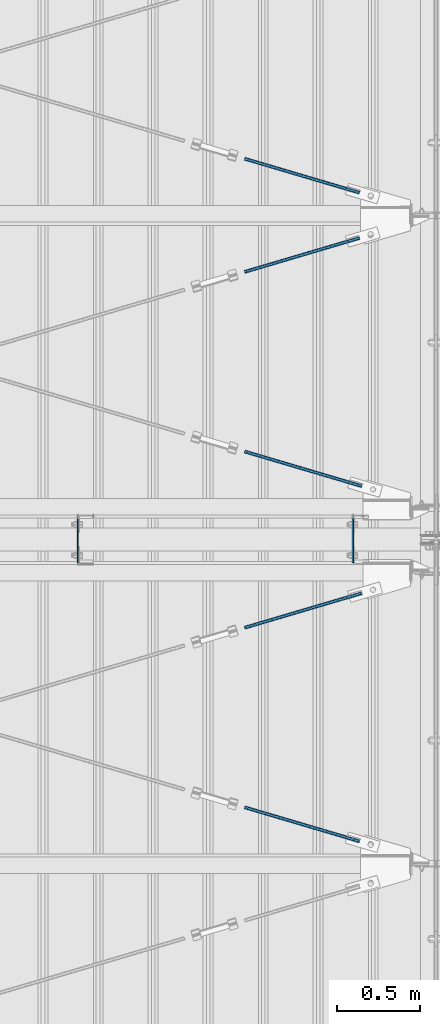
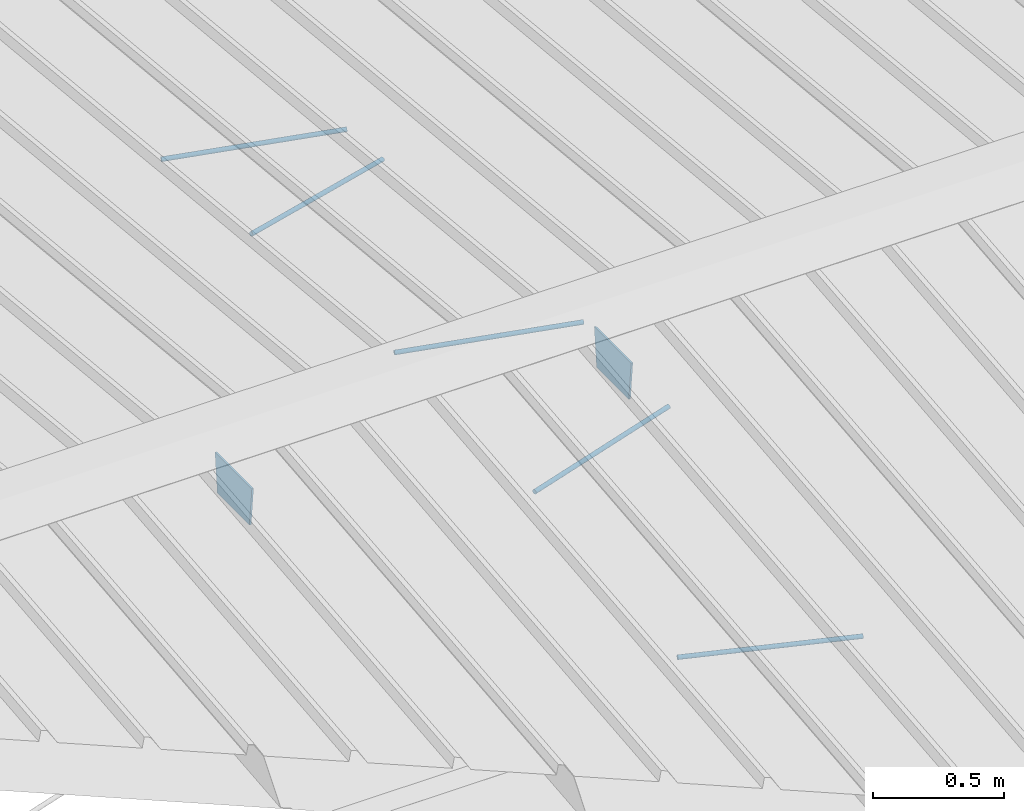
# One storey, part 296 of 709: 7 beams, 5 openings, 7 elements without a shape of their own.
"""IFC4 building model written with IfcOpenShell, lengths in millimetres."""

import ifcopenshell
import ifcopenshell.guid

model = None  # the IFC model being written
_history = None  # IfcOwnerHistory: only IFC2X3 demands one
_inside = {}  # id of a spatial element -> (the spatial element, [elements in it])
_under = {}  # id of a project, library or spatial element -> (it, [spatial elements below it])
_declared = {}  # id of a project -> (the project, [libraries it declares])
_typed = {}  # id of a type object -> (the type object, [elements of that type])
_made_of = {}  # id of a material, layer set ... -> (it, [elements and type objects made of it])


def new_model(schema):
    """Start an empty IFC model of exactly this schema.

    Asked for "IFC4X3", IfcOpenShell would pick the latest addendum, in which some entities
    have other attributes; the version numbers below select the first issue.
    IFC2X3 requires an IfcOwnerHistory on every rooted entity: one is made here for all.
    """
    global model, _history
    if schema == "IFC4X3":
        model = ifcopenshell.file(schema_version=(4, 3, 0, 0))
    else:
        model = ifcopenshell.file(schema=schema)
    _inside.clear()
    _under.clear()
    _declared.clear()
    _typed.clear()
    _made_of.clear()
    _history = None
    if model.schema == "IFC2X3":
        org = make("IfcOrganization", Name="unknown")
        user = make(
            "IfcPersonAndOrganization",
            ThePerson=make("IfcPerson", FamilyName="unknown"),
            TheOrganization=org,
        )
        app = make(
            "IfcApplication",
            ApplicationDeveloper=org,
            Version="unknown",
            ApplicationFullName="unknown",
            ApplicationIdentifier="unknown",
        )
        _history = make(
            "IfcOwnerHistory",
            OwningUser=user,
            OwningApplication=app,
            ChangeAction="ADDED",
            CreationDate=0,
        )
    return model


def make(cls, **values):
    """One entity of the class cls with the attributes given. An attribute that is None is left unset."""
    return model.create_entity(
        cls, **{name: value for name, value in values.items() if value is not None}
    )


def rooted(cls, **values):
    """An entity with a GlobalId (a new one), such as an element, a storey or a relation."""
    return make(cls, GlobalId=ifcopenshell.guid.new(), OwnerHistory=_history, **values)


def si_unit(unit_type, name, prefix=None):
    """IfcSIUnit, for example si_unit("LENGTHUNIT", "METRE", prefix="MILLI")."""
    return make("IfcSIUnit", UnitType=unit_type, Prefix=prefix, Name=name)


def assignment(units):
    """IfcUnitAssignment: the units of a project."""
    return None if units is None else make("IfcUnitAssignment", Units=units)


def point(xyz):
    """IfcCartesianPoint."""
    return None if xyz is None else make("IfcCartesianPoint", Coordinates=xyz)


def direction(xyz):
    """IfcDirection."""
    return None if xyz is None else make("IfcDirection", DirectionRatios=xyz)


def frame(location, z_axis=None, x_axis=None):
    """IfcAxis2Placement3D, a coordinate frame: its origin and axes. An axis left out is left unset."""
    return make(
        "IfcAxis2Placement3D",
        Location=point(location),
        Axis=direction(z_axis),
        RefDirection=direction(x_axis),
    )


def origin_with_axes():
    """The frame at (0, 0, 0) with the z axis (0, 0, 1) and the x axis (1, 0, 0) written out."""
    return frame((0.0, 0.0, 0.0), z_axis=(0.0, 0.0, 1.0), x_axis=(1.0, 0.0, 0.0))


def place(relative_to, where):
    """IfcLocalPlacement: puts the frame where relative to a parent placement (None: the world)."""
    return make(
        "IfcLocalPlacement", PlacementRelTo=relative_to, RelativePlacement=where
    )


def context(
    kind, dimensions, precision=None, world=None, true_north=None, identifier=None
):
    """IfcGeometricRepresentationContext, for example the 3D "Model" context."""
    return make(
        "IfcGeometricRepresentationContext",
        ContextIdentifier=identifier,
        ContextType=kind,
        CoordinateSpaceDimension=dimensions,
        Precision=precision,
        WorldCoordinateSystem=world,
        TrueNorth=true_north,
    )


def subcontext(parent, identifier, kind, view, scale=None):
    """IfcGeometricRepresentationSubContext, for example "Body" below "Model"."""
    return make(
        "IfcGeometricRepresentationSubContext",
        ContextIdentifier=identifier,
        ContextType=kind,
        ParentContext=parent,
        TargetScale=scale,
        TargetView=view,
    )


def project(units=None, contexts=None):
    """IfcProject with its units and contexts."""
    return rooted(
        "IfcProject",
        Name="project",
        RepresentationContexts=contexts,
        UnitsInContext=assignment(units),
    )


def spatial(cls, under=None, at=None, **own):
    """A site, building, storey or space (cls), placed at a placement, below another one or the project."""
    s = rooted(cls, ObjectPlacement=at, **own)
    if under is not None:
        _under.setdefault(under.id(), (under, []))[1].append(s)
    return s


def point_list(points):
    """IfcCartesianPointList2D or 3D."""
    cls = (
        "IfcCartesianPointList2D" if len(points[0]) == 2 else "IfcCartesianPointList3D"
    )
    return make(cls, CoordList=points)


def line(*indices):
    """IfcLineIndex: a straight run through numbered points of an indexed curve."""
    return model.create_entity("IfcLineIndex", indices)


def indexed_curve(points, segments=None, self_intersect=None):
    """IfcIndexedPolyCurve: lines and arcs through numbered points (the first is 1)."""
    return make(
        "IfcIndexedPolyCurve",
        Points=point_list(points),
        Segments=segments,
        SelfIntersect=self_intersect,
    )


def outline(outer, holes=None, kind="AREA"):
    """IfcArbitraryClosedProfileDef: a profile drawn as a closed curve; with holes, ...WithVoids."""
    if holes is None:
        return make("IfcArbitraryClosedProfileDef", ProfileType=kind, OuterCurve=outer)
    return make(
        "IfcArbitraryProfileDefWithVoids",
        ProfileType=kind,
        OuterCurve=outer,
        InnerCurves=holes,
    )


def extrude(swept, where, along, depth):
    """IfcExtrudedAreaSolid: the profile swept, set in the frame where, extruded along a direction by depth."""
    return make(
        "IfcExtrudedAreaSolid",
        SweptArea=swept,
        Position=where,
        ExtrudedDirection=direction(along),
        Depth=depth,
    )


def polygons(points, faces, closed=None, point_numbers=None):
    """IfcPolygonalFaceSet: a face is its outer loop, then its inner loops; points numbered from 1."""
    made = []
    for loops in faces:
        if len(loops) == 1:
            made.append(make("IfcIndexedPolygonalFace", CoordIndex=loops[0]))
        else:
            made.append(
                make(
                    "IfcIndexedPolygonalFaceWithVoids",
                    CoordIndex=loops[0],
                    InnerCoordIndices=loops[1:],
                )
            )
    return make(
        "IfcPolygonalFaceSet",
        Coordinates=point_list(points),
        Closed=closed,
        Faces=made,
        PnIndex=point_numbers,
    )


def shape(context_of_items, identifier, shape_type, items):
    """IfcShapeRepresentation: the items that make up one representation, for example the "Body"."""
    return make(
        "IfcShapeRepresentation",
        ContextOfItems=context_of_items,
        RepresentationIdentifier=identifier,
        RepresentationType=shape_type,
        Items=items,
    )


def material(Name=None, Category=None):
    """IfcMaterial."""
    return make("IfcMaterial", Name=Name, Category=Category)


def made_of(thing, what):
    """Note that an element or type object is made of a material, layer set ...; save() writes the relation."""
    if what is not None:
        _made_of.setdefault(what.id(), (what, []))[1].append(thing)
    return thing


def element(
    cls,
    number,
    at=None,
    inside=None,
    cuts=None,
    type_object=None,
    material=None,
    context=None,
    identifier="Body",
    shape_type=None,
    held_by="IfcProductDefinitionShape",
    body=None,
    shapes=None,
    **own,
):
    """One element of the class cls, such as IfcWall. Its Tag is "e" and its number.

    at: its placement. inside: the storey or other place that contains it. cuts: it is an
    opening in that element (IfcRelVoidsElement). A single representation is given by context,
    identifier, shape_type and body (its items); several are given by shapes. held_by: the class
    of the entity that holds the representations. save() writes the other relations.
    """
    e = rooted(cls, Tag="e%d" % number, ObjectPlacement=at, **own)
    if body is not None:
        shapes = [shape(context, identifier, shape_type, body)]
    if shapes is not None:
        e.Representation = make(held_by, Representations=shapes)
    if inside is not None:
        _inside.setdefault(inside.id(), (inside, []))[1].append(e)
    if cuts is not None:
        rooted(
            "IfcRelVoidsElement", RelatingBuildingElement=cuts, RelatedOpeningElement=e
        )
    if type_object is not None:
        _typed.setdefault(type_object.id(), (type_object, []))[1].append(e)
    return made_of(e, material)


def aggregate(whole, parts):
    """IfcRelAggregates: a whole, such as a stair, and the parts it consists of."""
    return rooted("IfcRelAggregates", RelatingObject=whole, RelatedObjects=parts)


def save(model, path):
    """Write the relations noted so far, then the file.

    IfcRelAggregates (storeys below a building ...), IfcRelContainedInSpatialStructure (elements
    in a storey), IfcRelDefinesByType, IfcRelAssociatesMaterial and IfcRelDeclares: one each for
    every whole, place, type object, material and project.
    """
    for whole, parts in _under.values():
        aggregate(whole, parts)
    for where, things in _inside.values():
        rooted(
            "IfcRelContainedInSpatialStructure",
            RelatedElements=things,
            RelatingStructure=where,
        )
    for kind, things in _typed.values():
        rooted("IfcRelDefinesByType", RelatedObjects=things, RelatingType=kind)
    for what, things in _made_of.values():
        rooted("IfcRelAssociatesMaterial", RelatedObjects=things, RelatingMaterial=what)
    for by, libraries in _declared.values():
        rooted("IfcRelDeclares", RelatingContext=by, RelatedDefinitions=libraries)
    model.write(path)


model = new_model("IFC4")

# Units and contexts
model_context = context("Model", 3, precision=0.2, world=origin_with_axes(), true_north=direction((0.0, 1.0)))
body_context = subcontext(model_context, "Body", "Model", "MODEL_VIEW")
reference_context = subcontext(model_context, "Reference", "Model", "MODEL_VIEW")
ifc_project = project(units=[si_unit("LENGTHUNIT", "METRE", prefix="MILLI"), si_unit("AREAUNIT", "SQUARE_METRE"), si_unit("VOLUMEUNIT", "CUBIC_METRE"), si_unit("MASSUNIT", "GRAM", prefix="KILO"), si_unit("TIMEUNIT", "SECOND"), si_unit("PLANEANGLEUNIT", "RADIAN"), si_unit("SOLIDANGLEUNIT", "STERADIAN"), si_unit("THERMODYNAMICTEMPERATUREUNIT", "DEGREE_CELSIUS"), si_unit("LUMINOUSINTENSITYUNIT", "LUMEN")], contexts=[model_context])

# Site, building, storey
site_placement = place(None, origin_with_axes())
site = spatial("IfcSite", under=ifc_project, at=site_placement, CompositionType="ELEMENT")
building_placement = place(site_placement, origin_with_axes())
building = spatial("IfcBuilding", under=site, at=building_placement, Name="Undefined", CompositionType="ELEMENT")
storey_placement = place(building_placement, origin_with_axes())
storey = spatial("IfcBuildingStorey", under=building, at=storey_placement, Name="Undefined", CompositionType="ELEMENT", Elevation=0.0)

# Assembly, beam, voiding feature
assembly_1_placement = place(storey_placement, frame((8657.949, 10412.51111, 8177.75513), z_axis=(0.2847296511, -0.9538504697, -0.095385047), x_axis=(0.9586078582, 0.2833165921, 0.028331659)))
assembly_1 = element("IfcElementAssembly", 1, at=assembly_1_placement, inside=storey)
ifc_material_1 = material(Name="C355-5", Category="STEEL")
beam_1_placement = place(assembly_1_placement, origin_with_axes())
beam_1 = element("IfcBeam", 2, at=beam_1_placement, material=ifc_material_1, ObjectType="571", context=body_context, shape_type="Tessellation", body=[
    polygons([(931.31721, -5.0, 8.66025), (931.31721, -7.07107, 7.07107), (931.31721, -8.66025, 5.0), (931.31721, -9.65926, 2.58819), (931.31721, -10.0, 0.0), (931.31721, -9.65926, -2.58819), (931.31721, -8.66025, -5.0), (931.31721, -7.07107, -7.07107), (931.31721, -5.0, -8.66025), (931.31721, -2.58819, -9.65926), (931.31721, 0.0, -10.0), (931.31721, 2.58819, -9.65926), (931.31721, 5.0, -8.66025), (931.31721, 7.07107, -7.07107), (931.31721, 8.66025, -5.0), (931.31721, 9.65926, -2.58819), (931.31721, 10.0, 0.0), (931.31721, 9.65926, 2.58819), (931.31721, 8.66025, 5.0), (931.31721, 7.07107, 7.07107), (931.31721, 5.0, 8.66025), (931.31721, 2.58819, 9.65926), (931.31721, 0.0, 10.0), (931.31721, -2.58819, 9.65926), (190.0, 10.0, 0.0), (190.0, 9.65926, 2.58819), (190.0, 8.66025, 5.0), (190.0, 7.07107, 7.07107), (190.0, 5.0, 8.66025), (190.0, 2.58819, 9.65926), (190.0, 0.0, 10.0), (190.0, -2.58819, 9.65926), (190.0, -5.0, 8.66025), (190.0, -7.07107, 7.07107), (190.0, -8.66025, 5.0), (190.0, -9.65926, 2.58819), (190.0, -10.0, 0.0), (190.0, -9.65926, -2.58819), (190.0, -8.66025, -5.0), (190.0, -7.07107, -7.07107), (190.0, -5.0, -8.66025), (190.0, -2.58819, -9.65926), (190.0, 0.0, -10.0), (190.0, 2.58819, -9.65926), (190.0, 5.0, -8.66025), (190.0, 7.07107, -7.07107), (190.0, 8.66025, -5.0), (190.0, 9.65926, -2.58819), (10.0, 7.36122, 4.25), (190.0, 7.36122, 4.25), (190.0, 8.21037, 2.19996), (10.0, 8.21037, 2.19996), (10.0, 6.01041, 6.01041), (190.0, 6.01041, 6.01041), (10.0, 4.25, 7.36122), (190.0, 4.25, 7.36122), (10.0, 2.19996, 8.21037), (190.0, 2.19996, 8.21037), (10.0, 0.0, 8.5), (190.0, 0.0, 8.5), (10.0, -2.19996, 8.21037), (190.0, -2.19996, 8.21037), (10.0, -4.25, 7.36122), (190.0, -4.25, 7.36122), (10.0, -6.01041, 6.01041), (190.0, -6.01041, 6.01041), (10.0, -7.36122, 4.25), (190.0, -7.36122, 4.25), (10.0, -8.21037, 2.19996), (190.0, -8.21037, 2.19996), (10.0, -8.5, 0.0), (190.0, -8.5, 0.0), (10.0, -8.21037, -2.19996), (190.0, -8.21037, -2.19996), (10.0, -7.36122, -4.25), (190.0, -7.36122, -4.25), (10.0, -6.01041, -6.01041), (190.0, -6.01041, -6.01041), (10.0, -4.25, -7.36122), (190.0, -4.25, -7.36122), (10.0, -2.19996, -8.21037), (190.0, -2.19996, -8.21037), (10.0, 0.0, -8.5), (190.0, 0.0, -8.5), (10.0, 2.19996, -8.21037), (190.0, 2.19996, -8.21037), (10.0, 4.25, -7.36122), (190.0, 4.25, -7.36122), (10.0, 6.01041, -6.01041), (190.0, 6.01041, -6.01041), (10.0, 7.36122, -4.25), (190.0, 7.36122, -4.25), (10.0, 8.21037, -2.19996), (190.0, 8.21037, -2.19996), (10.0, 8.5, 0.0), (190.0, 8.5, 0.0)], [[[1, 2, 3, 4, 5, 6, 7, 8, 9, 10, 11, 12, 13, 14, 15, 16, 17, 18, 19, 20, 21, 22, 23, 24]], [[18, 17, 25, 26]], [[19, 18, 26, 27]], [[20, 19, 27, 28]], [[21, 20, 28, 29]], [[22, 21, 29, 30]], [[23, 22, 30, 31]], [[24, 23, 31, 32]], [[1, 24, 32, 33]], [[2, 1, 33, 34]], [[3, 2, 34, 35]], [[4, 3, 35, 36]], [[5, 4, 36, 37]], [[6, 5, 37, 38]], [[7, 6, 38, 39]], [[8, 7, 39, 40]], [[9, 8, 40, 41]], [[10, 9, 41, 42]], [[11, 10, 42, 43]], [[12, 11, 43, 44]], [[13, 12, 44, 45]], [[14, 13, 45, 46]], [[15, 14, 46, 47]], [[16, 15, 47, 48]], [[17, 16, 48, 25]], [[25, 48, 47, 46, 45, 44, 43, 42, 41, 40, 39, 38, 37, 36, 35, 34, 33, 32, 31, 30, 29, 28, 27, 26], [74, 76, 78, 80, 82, 84, 86, 88, 90, 92, 94, 96, 51, 50, 54, 56, 58, 60, 62, 64, 66, 68, 70, 72]], [[49, 50, 51, 52]], [[53, 54, 50, 49]], [[55, 56, 54, 53]], [[57, 58, 56, 55]], [[59, 60, 58, 57]], [[61, 62, 60, 59]], [[63, 64, 62, 61]], [[65, 66, 64, 63]], [[67, 68, 66, 65]], [[69, 70, 68, 67]], [[71, 72, 70, 69]], [[73, 74, 72, 71]], [[75, 76, 74, 73]], [[77, 78, 76, 75]], [[79, 80, 78, 77]], [[81, 82, 80, 79]], [[83, 84, 82, 81]], [[85, 86, 84, 83]], [[87, 88, 86, 85]], [[89, 90, 88, 87]], [[91, 92, 90, 89]], [[93, 94, 92, 91]], [[95, 96, 94, 93]], [[52, 51, 96, 95]], [[91, 89, 87, 85, 83, 81, 79, 77, 75, 73, 71, 69, 67, 65, 63, 61, 59, 57, 55, 53, 49, 52, 95, 93]]], closed=True),
])
voiding_feature_1_placement = place(beam_1_placement, frame((10.0, 0.0, 0.0), z_axis=(0.0, -1.0, 0.0), x_axis=(1.0, 0.0, 0.0)))
element("IfcVoidingFeature", 3, at=voiding_feature_1_placement, cuts=beam_1, PredefinedType="HOLE", context=reference_context, identifier="Reference", shape_type="SolidModel", body=[
    extrude(outline(indexed_curve([(10.5, 0.0), (10.14222, 2.7176), (9.09327, 5.25), (7.42462, 7.42462), (5.25, 9.09327), (2.7176, 10.14222), (0.0, 10.5), (-2.7176, 10.14222), (-5.25, 9.09327), (-7.42462, 7.42462), (-9.09327, 5.25), (-10.14222, 2.7176), (-10.5, 0.0), (-10.14222, -2.7176), (-9.09327, -5.25), (-7.42462, -7.42462), (-5.25, -9.09327), (-2.7176, -10.14222), (0.0, -10.5), (2.7176, -10.14222), (5.25, -9.09327), (7.42462, -7.42462), (9.09327, -5.25), (10.14222, -2.7176)], segments=[line(1, 2, 3, 4, 5, 6, 7, 8, 9, 10, 11, 12, 13, 14, 15, 16, 17, 18, 19, 20, 21, 22, 23, 24, 1)])), frame((0.0, 0.0, 0.0), z_axis=(-1.0, 0.0, 0.0), x_axis=(0.0, 0.0, 1.0)), (0.0, 0.0, -1.0), 180.0),
])
aggregate(assembly_1, [beam_1])

assembly_2_placement = place(storey_placement, frame((8657.949, 9432.49732, 8079.75375), z_axis=(-0.2847296511, -0.9538504697, -0.095385047), x_axis=(0.9586078582, -0.2833165921, -0.028331659)))
assembly_2 = element("IfcElementAssembly", 4, at=assembly_2_placement, inside=storey)
beam_2_placement = place(assembly_2_placement, origin_with_axes())
beam_2 = element("IfcBeam", 5, at=beam_2_placement, material=ifc_material_1, ObjectType="569", context=body_context, shape_type="Tessellation", body=[
    polygons([(916.31721, -5.0, 8.66025), (916.31721, -7.07107, 7.07107), (916.31721, -8.66025, 5.0), (916.31721, -9.65926, 2.58819), (916.31721, -10.0, 0.0), (916.31721, -9.65926, -2.58819), (916.31721, -8.66025, -5.0), (916.31721, -7.07107, -7.07107), (916.31721, -5.0, -8.66025), (916.31721, -2.58819, -9.65926), (916.31721, 0.0, -10.0), (916.31721, 2.58819, -9.65926), (916.31721, 5.0, -8.66025), (916.31721, 7.07107, -7.07107), (916.31721, 8.66025, -5.0), (916.31721, 9.65926, -2.58819), (916.31721, 10.0, 0.0), (916.31721, 9.65926, 2.58819), (916.31721, 8.66025, 5.0), (916.31721, 7.07107, 7.07107), (916.31721, 5.0, 8.66025), (916.31721, 2.58819, 9.65926), (916.31721, 0.0, 10.0), (916.31721, -2.58819, 9.65926), (190.0, 10.0, 0.0), (190.0, 9.65926, 2.58819), (190.0, 8.66025, 5.0), (190.0, 7.07107, 7.07107), (190.0, 5.0, 8.66025), (190.0, 2.58819, 9.65926), (190.0, 0.0, 10.0), (190.0, -2.58819, 9.65926), (190.0, -5.0, 8.66025), (190.0, -7.07107, 7.07107), (190.0, -8.66025, 5.0), (190.0, -9.65926, 2.58819), (190.0, -10.0, 0.0), (190.0, -9.65926, -2.58819), (190.0, -8.66025, -5.0), (190.0, -7.07107, -7.07107), (190.0, -5.0, -8.66025), (190.0, -2.58819, -9.65926), (190.0, 0.0, -10.0), (190.0, 2.58819, -9.65926), (190.0, 5.0, -8.66025), (190.0, 7.07107, -7.07107), (190.0, 8.66025, -5.0), (190.0, 9.65926, -2.58819), (10.0, 7.36122, 4.25), (190.0, 7.36122, 4.25), (190.0, 8.21037, 2.19996), (10.0, 8.21037, 2.19996), (10.0, 6.01041, 6.01041), (190.0, 6.01041, 6.01041), (10.0, 4.25, 7.36122), (190.0, 4.25, 7.36122), (10.0, 2.19996, 8.21037), (190.0, 2.19996, 8.21037), (10.0, 0.0, 8.5), (190.0, 0.0, 8.5), (10.0, -2.19996, 8.21037), (190.0, -2.19996, 8.21037), (10.0, -4.25, 7.36122), (190.0, -4.25, 7.36122), (10.0, -6.01041, 6.01041), (190.0, -6.01041, 6.01041), (10.0, -7.36122, 4.25), (190.0, -7.36122, 4.25), (10.0, -8.21037, 2.19996), (190.0, -8.21037, 2.19996), (10.0, -8.5, 0.0), (190.0, -8.5, 0.0), (10.0, -8.21037, -2.19996), (190.0, -8.21037, -2.19996), (10.0, -7.36122, -4.25), (190.0, -7.36122, -4.25), (10.0, -6.01041, -6.01041), (190.0, -6.01041, -6.01041), (10.0, -4.25, -7.36122), (190.0, -4.25, -7.36122), (10.0, -2.19996, -8.21037), (190.0, -2.19996, -8.21037), (10.0, 0.0, -8.5), (190.0, 0.0, -8.5), (10.0, 2.19996, -8.21037), (190.0, 2.19996, -8.21037), (10.0, 4.25, -7.36122), (190.0, 4.25, -7.36122), (10.0, 6.01041, -6.01041), (190.0, 6.01041, -6.01041), (10.0, 7.36122, -4.25), (190.0, 7.36122, -4.25), (10.0, 8.21037, -2.19996), (190.0, 8.21037, -2.19996), (10.0, 8.5, 0.0), (190.0, 8.5, 0.0)], [[[1, 2, 3, 4, 5, 6, 7, 8, 9, 10, 11, 12, 13, 14, 15, 16, 17, 18, 19, 20, 21, 22, 23, 24]], [[18, 17, 25, 26]], [[19, 18, 26, 27]], [[20, 19, 27, 28]], [[21, 20, 28, 29]], [[22, 21, 29, 30]], [[23, 22, 30, 31]], [[24, 23, 31, 32]], [[1, 24, 32, 33]], [[2, 1, 33, 34]], [[3, 2, 34, 35]], [[4, 3, 35, 36]], [[5, 4, 36, 37]], [[6, 5, 37, 38]], [[7, 6, 38, 39]], [[8, 7, 39, 40]], [[9, 8, 40, 41]], [[10, 9, 41, 42]], [[11, 10, 42, 43]], [[12, 11, 43, 44]], [[13, 12, 44, 45]], [[14, 13, 45, 46]], [[15, 14, 46, 47]], [[16, 15, 47, 48]], [[17, 16, 48, 25]], [[25, 48, 47, 46, 45, 44, 43, 42, 41, 40, 39, 38, 37, 36, 35, 34, 33, 32, 31, 30, 29, 28, 27, 26], [74, 76, 78, 80, 82, 84, 86, 88, 90, 92, 94, 96, 51, 50, 54, 56, 58, 60, 62, 64, 66, 68, 70, 72]], [[49, 50, 51, 52]], [[53, 54, 50, 49]], [[55, 56, 54, 53]], [[57, 58, 56, 55]], [[59, 60, 58, 57]], [[61, 62, 60, 59]], [[63, 64, 62, 61]], [[65, 66, 64, 63]], [[67, 68, 66, 65]], [[69, 70, 68, 67]], [[71, 72, 70, 69]], [[73, 74, 72, 71]], [[75, 76, 74, 73]], [[77, 78, 76, 75]], [[79, 80, 78, 77]], [[81, 82, 80, 79]], [[83, 84, 82, 81]], [[85, 86, 84, 83]], [[87, 88, 86, 85]], [[89, 90, 88, 87]], [[91, 92, 90, 89]], [[93, 94, 92, 91]], [[95, 96, 94, 93]], [[52, 51, 96, 95]], [[91, 89, 87, 85, 83, 81, 79, 77, 75, 73, 71, 69, 67, 65, 63, 61, 59, 57, 55, 53, 49, 52, 95, 93]]], closed=True),
])
voiding_feature_2_placement = place(beam_2_placement, frame((10.0, 0.0, 0.0), z_axis=(0.0, -1.0, 0.0), x_axis=(1.0, 0.0, 0.0)))
element("IfcVoidingFeature", 6, at=voiding_feature_2_placement, cuts=beam_2, PredefinedType="HOLE", context=reference_context, identifier="Reference", shape_type="SolidModel", body=[
    extrude(outline(indexed_curve([(10.5, 0.0), (10.14222, 2.7176), (9.09327, 5.25), (7.42462, 7.42462), (5.25, 9.09327), (2.7176, 10.14222), (0.0, 10.5), (-2.7176, 10.14222), (-5.25, 9.09327), (-7.42462, 7.42462), (-9.09327, 5.25), (-10.14222, 2.7176), (-10.5, 0.0), (-10.14222, -2.7176), (-9.09327, -5.25), (-7.42462, -7.42462), (-5.25, -9.09327), (-2.7176, -10.14222), (0.0, -10.5), (2.7176, -10.14222), (5.25, -9.09327), (7.42462, -7.42462), (9.09327, -5.25), (10.14222, -2.7176)], segments=[line(1, 2, 3, 4, 5, 6, 7, 8, 9, 10, 11, 12, 13, 14, 15, 16, 17, 18, 19, 20, 21, 22, 23, 24, 1)])), frame((0.0, 0.0, 0.0), z_axis=(-1.0, 0.0, 0.0), x_axis=(0.0, 0.0, 1.0)), (0.0, 0.0, -1.0), 180.0),
])
aggregate(assembly_2, [beam_2])

assembly_3_placement = place(storey_placement, frame((8657.949, 12567.50268, 8079.75375), z_axis=(0.2847296511, -0.9538504697, 0.095385047), x_axis=(0.9586078582, 0.2833165921, -0.028331659)))
assembly_3 = element("IfcElementAssembly", 7, at=assembly_3_placement, inside=storey)
beam_3_placement = place(assembly_3_placement, origin_with_axes())
beam_3 = element("IfcBeam", 8, at=beam_3_placement, material=ifc_material_1, ObjectType="569", context=body_context, shape_type="Tessellation", body=[
    polygons([(916.31721, -5.0, 8.66025), (916.31721, -7.07107, 7.07107), (916.31721, -8.66025, 5.0), (916.31721, -9.65926, 2.58819), (916.31721, -10.0, 0.0), (916.31721, -9.65926, -2.58819), (916.31721, -8.66025, -5.0), (916.31721, -7.07107, -7.07107), (916.31721, -5.0, -8.66025), (916.31721, -2.58819, -9.65926), (916.31721, 0.0, -10.0), (916.31721, 2.58819, -9.65926), (916.31721, 5.0, -8.66025), (916.31721, 7.07107, -7.07107), (916.31721, 8.66025, -5.0), (916.31721, 9.65926, -2.58819), (916.31721, 10.0, 0.0), (916.31721, 9.65926, 2.58819), (916.31721, 8.66025, 5.0), (916.31721, 7.07107, 7.07107), (916.31721, 5.0, 8.66025), (916.31721, 2.58819, 9.65926), (916.31721, 0.0, 10.0), (916.31721, -2.58819, 9.65926), (190.0, 10.0, 0.0), (190.0, 9.65926, 2.58819), (190.0, 8.66025, 5.0), (190.0, 7.07107, 7.07107), (190.0, 5.0, 8.66025), (190.0, 2.58819, 9.65926), (190.0, 0.0, 10.0), (190.0, -2.58819, 9.65926), (190.0, -5.0, 8.66025), (190.0, -7.07107, 7.07107), (190.0, -8.66025, 5.0), (190.0, -9.65926, 2.58819), (190.0, -10.0, 0.0), (190.0, -9.65926, -2.58819), (190.0, -8.66025, -5.0), (190.0, -7.07107, -7.07107), (190.0, -5.0, -8.66025), (190.0, -2.58819, -9.65926), (190.0, 0.0, -10.0), (190.0, 2.58819, -9.65926), (190.0, 5.0, -8.66025), (190.0, 7.07107, -7.07107), (190.0, 8.66025, -5.0), (190.0, 9.65926, -2.58819), (10.0, 7.36122, 4.25), (190.0, 7.36122, 4.25), (190.0, 8.21037, 2.19996), (10.0, 8.21037, 2.19996), (10.0, 6.01041, 6.01041), (190.0, 6.01041, 6.01041), (10.0, 4.25, 7.36122), (190.0, 4.25, 7.36122), (10.0, 2.19996, 8.21037), (190.0, 2.19996, 8.21037), (10.0, 0.0, 8.5), (190.0, 0.0, 8.5), (10.0, -2.19996, 8.21037), (190.0, -2.19996, 8.21037), (10.0, -4.25, 7.36122), (190.0, -4.25, 7.36122), (10.0, -6.01041, 6.01041), (190.0, -6.01041, 6.01041), (10.0, -7.36122, 4.25), (190.0, -7.36122, 4.25), (10.0, -8.21037, 2.19996), (190.0, -8.21037, 2.19996), (10.0, -8.5, 0.0), (190.0, -8.5, 0.0), (10.0, -8.21037, -2.19996), (190.0, -8.21037, -2.19996), (10.0, -7.36122, -4.25), (190.0, -7.36122, -4.25), (10.0, -6.01041, -6.01041), (190.0, -6.01041, -6.01041), (10.0, -4.25, -7.36122), (190.0, -4.25, -7.36122), (10.0, -2.19996, -8.21037), (190.0, -2.19996, -8.21037), (10.0, 0.0, -8.5), (190.0, 0.0, -8.5), (10.0, 2.19996, -8.21037), (190.0, 2.19996, -8.21037), (10.0, 4.25, -7.36122), (190.0, 4.25, -7.36122), (10.0, 6.01041, -6.01041), (190.0, 6.01041, -6.01041), (10.0, 7.36122, -4.25), (190.0, 7.36122, -4.25), (10.0, 8.21037, -2.19996), (190.0, 8.21037, -2.19996), (10.0, 8.5, 0.0), (190.0, 8.5, 0.0)], [[[1, 2, 3, 4, 5, 6, 7, 8, 9, 10, 11, 12, 13, 14, 15, 16, 17, 18, 19, 20, 21, 22, 23, 24]], [[18, 17, 25, 26]], [[19, 18, 26, 27]], [[20, 19, 27, 28]], [[21, 20, 28, 29]], [[22, 21, 29, 30]], [[23, 22, 30, 31]], [[24, 23, 31, 32]], [[1, 24, 32, 33]], [[2, 1, 33, 34]], [[3, 2, 34, 35]], [[4, 3, 35, 36]], [[5, 4, 36, 37]], [[6, 5, 37, 38]], [[7, 6, 38, 39]], [[8, 7, 39, 40]], [[9, 8, 40, 41]], [[10, 9, 41, 42]], [[11, 10, 42, 43]], [[12, 11, 43, 44]], [[13, 12, 44, 45]], [[14, 13, 45, 46]], [[15, 14, 46, 47]], [[16, 15, 47, 48]], [[17, 16, 48, 25]], [[25, 48, 47, 46, 45, 44, 43, 42, 41, 40, 39, 38, 37, 36, 35, 34, 33, 32, 31, 30, 29, 28, 27, 26], [74, 76, 78, 80, 82, 84, 86, 88, 90, 92, 94, 96, 51, 50, 54, 56, 58, 60, 62, 64, 66, 68, 70, 72]], [[49, 50, 51, 52]], [[53, 54, 50, 49]], [[55, 56, 54, 53]], [[57, 58, 56, 55]], [[59, 60, 58, 57]], [[61, 62, 60, 59]], [[63, 64, 62, 61]], [[65, 66, 64, 63]], [[67, 68, 66, 65]], [[69, 70, 68, 67]], [[71, 72, 70, 69]], [[73, 74, 72, 71]], [[75, 76, 74, 73]], [[77, 78, 76, 75]], [[79, 80, 78, 77]], [[81, 82, 80, 79]], [[83, 84, 82, 81]], [[85, 86, 84, 83]], [[87, 88, 86, 85]], [[89, 90, 88, 87]], [[91, 92, 90, 89]], [[93, 94, 92, 91]], [[95, 96, 94, 93]], [[52, 51, 96, 95]], [[91, 89, 87, 85, 83, 81, 79, 77, 75, 73, 71, 69, 67, 65, 63, 61, 59, 57, 55, 53, 49, 52, 95, 93]]], closed=True),
])
voiding_feature_3_placement = place(beam_3_placement, frame((10.0, 0.0, 0.0), z_axis=(0.0, -1.0, 0.0), x_axis=(1.0, 0.0, 0.0)))
element("IfcVoidingFeature", 9, at=voiding_feature_3_placement, cuts=beam_3, PredefinedType="HOLE", context=reference_context, identifier="Reference", shape_type="SolidModel", body=[
    extrude(outline(indexed_curve([(10.5, 0.0), (10.14222, 2.7176), (9.09327, 5.25), (7.42462, 7.42462), (5.25, 9.09327), (2.7176, 10.14222), (0.0, 10.5), (-2.7176, 10.14222), (-5.25, 9.09327), (-7.42462, 7.42462), (-9.09327, 5.25), (-10.14222, 2.7176), (-10.5, 0.0), (-10.14222, -2.7176), (-9.09327, -5.25), (-7.42462, -7.42462), (-5.25, -9.09327), (-2.7176, -10.14222), (0.0, -10.5), (2.7176, -10.14222), (5.25, -9.09327), (7.42462, -7.42462), (9.09327, -5.25), (10.14222, -2.7176)], segments=[line(1, 2, 3, 4, 5, 6, 7, 8, 9, 10, 11, 12, 13, 14, 15, 16, 17, 18, 19, 20, 21, 22, 23, 24, 1)])), frame((0.0, 0.0, 0.0), z_axis=(-1.0, 0.0, 0.0), x_axis=(0.0, 0.0, 1.0)), (0.0, 0.0, -1.0), 180.0),
])
aggregate(assembly_3, [beam_3])

assembly_4_placement = place(storey_placement, frame((8657.949, 11587.48889, 8177.75513), z_axis=(-0.2847296511, -0.9538504697, 0.095385047), x_axis=(0.9586078582, -0.2833165921, 0.028331659)))
assembly_4 = element("IfcElementAssembly", 10, at=assembly_4_placement, inside=storey)
beam_4_placement = place(assembly_4_placement, origin_with_axes())
beam_4 = element("IfcBeam", 11, at=beam_4_placement, material=ifc_material_1, ObjectType="571", context=body_context, shape_type="Tessellation", body=[
    polygons([(931.31721, -5.0, 8.66025), (931.31721, -7.07107, 7.07107), (931.31721, -8.66025, 5.0), (931.31721, -9.65926, 2.58819), (931.31721, -10.0, 0.0), (931.31721, -9.65926, -2.58819), (931.31721, -8.66025, -5.0), (931.31721, -7.07107, -7.07107), (931.31721, -5.0, -8.66025), (931.31721, -2.58819, -9.65926), (931.31721, 0.0, -10.0), (931.31721, 2.58819, -9.65926), (931.31721, 5.0, -8.66025), (931.31721, 7.07107, -7.07107), (931.31721, 8.66025, -5.0), (931.31721, 9.65926, -2.58819), (931.31721, 10.0, 0.0), (931.31721, 9.65926, 2.58819), (931.31721, 8.66025, 5.0), (931.31721, 7.07107, 7.07107), (931.31721, 5.0, 8.66025), (931.31721, 2.58819, 9.65926), (931.31721, 0.0, 10.0), (931.31721, -2.58819, 9.65926), (190.0, 10.0, 0.0), (190.0, 9.65926, 2.58819), (190.0, 8.66025, 5.0), (190.0, 7.07107, 7.07107), (190.0, 5.0, 8.66025), (190.0, 2.58819, 9.65926), (190.0, 0.0, 10.0), (190.0, -2.58819, 9.65926), (190.0, -5.0, 8.66025), (190.0, -7.07107, 7.07107), (190.0, -8.66025, 5.0), (190.0, -9.65926, 2.58819), (190.0, -10.0, 0.0), (190.0, -9.65926, -2.58819), (190.0, -8.66025, -5.0), (190.0, -7.07107, -7.07107), (190.0, -5.0, -8.66025), (190.0, -2.58819, -9.65926), (190.0, 0.0, -10.0), (190.0, 2.58819, -9.65926), (190.0, 5.0, -8.66025), (190.0, 7.07107, -7.07107), (190.0, 8.66025, -5.0), (190.0, 9.65926, -2.58819), (10.0, 7.36122, 4.25), (190.0, 7.36122, 4.25), (190.0, 8.21037, 2.19996), (10.0, 8.21037, 2.19996), (10.0, 6.01041, 6.01041), (190.0, 6.01041, 6.01041), (10.0, 4.25, 7.36122), (190.0, 4.25, 7.36122), (10.0, 2.19996, 8.21037), (190.0, 2.19996, 8.21037), (10.0, 0.0, 8.5), (190.0, 0.0, 8.5), (10.0, -2.19996, 8.21037), (190.0, -2.19996, 8.21037), (10.0, -4.25, 7.36122), (190.0, -4.25, 7.36122), (10.0, -6.01041, 6.01041), (190.0, -6.01041, 6.01041), (10.0, -7.36122, 4.25), (190.0, -7.36122, 4.25), (10.0, -8.21037, 2.19996), (190.0, -8.21037, 2.19996), (10.0, -8.5, 0.0), (190.0, -8.5, 0.0), (10.0, -8.21037, -2.19996), (190.0, -8.21037, -2.19996), (10.0, -7.36122, -4.25), (190.0, -7.36122, -4.25), (10.0, -6.01041, -6.01041), (190.0, -6.01041, -6.01041), (10.0, -4.25, -7.36122), (190.0, -4.25, -7.36122), (10.0, -2.19996, -8.21037), (190.0, -2.19996, -8.21037), (10.0, 0.0, -8.5), (190.0, 0.0, -8.5), (10.0, 2.19996, -8.21037), (190.0, 2.19996, -8.21037), (10.0, 4.25, -7.36122), (190.0, 4.25, -7.36122), (10.0, 6.01041, -6.01041), (190.0, 6.01041, -6.01041), (10.0, 7.36122, -4.25), (190.0, 7.36122, -4.25), (10.0, 8.21037, -2.19996), (190.0, 8.21037, -2.19996), (10.0, 8.5, 0.0), (190.0, 8.5, 0.0)], [[[1, 2, 3, 4, 5, 6, 7, 8, 9, 10, 11, 12, 13, 14, 15, 16, 17, 18, 19, 20, 21, 22, 23, 24]], [[18, 17, 25, 26]], [[19, 18, 26, 27]], [[20, 19, 27, 28]], [[21, 20, 28, 29]], [[22, 21, 29, 30]], [[23, 22, 30, 31]], [[24, 23, 31, 32]], [[1, 24, 32, 33]], [[2, 1, 33, 34]], [[3, 2, 34, 35]], [[4, 3, 35, 36]], [[5, 4, 36, 37]], [[6, 5, 37, 38]], [[7, 6, 38, 39]], [[8, 7, 39, 40]], [[9, 8, 40, 41]], [[10, 9, 41, 42]], [[11, 10, 42, 43]], [[12, 11, 43, 44]], [[13, 12, 44, 45]], [[14, 13, 45, 46]], [[15, 14, 46, 47]], [[16, 15, 47, 48]], [[17, 16, 48, 25]], [[25, 48, 47, 46, 45, 44, 43, 42, 41, 40, 39, 38, 37, 36, 35, 34, 33, 32, 31, 30, 29, 28, 27, 26], [74, 76, 78, 80, 82, 84, 86, 88, 90, 92, 94, 96, 51, 50, 54, 56, 58, 60, 62, 64, 66, 68, 70, 72]], [[49, 50, 51, 52]], [[53, 54, 50, 49]], [[55, 56, 54, 53]], [[57, 58, 56, 55]], [[59, 60, 58, 57]], [[61, 62, 60, 59]], [[63, 64, 62, 61]], [[65, 66, 64, 63]], [[67, 68, 66, 65]], [[69, 70, 68, 67]], [[71, 72, 70, 69]], [[73, 74, 72, 71]], [[75, 76, 74, 73]], [[77, 78, 76, 75]], [[79, 80, 78, 77]], [[81, 82, 80, 79]], [[83, 84, 82, 81]], [[85, 86, 84, 83]], [[87, 88, 86, 85]], [[89, 90, 88, 87]], [[91, 92, 90, 89]], [[93, 94, 92, 91]], [[95, 96, 94, 93]], [[52, 51, 96, 95]], [[91, 89, 87, 85, 83, 81, 79, 77, 75, 73, 71, 69, 67, 65, 63, 61, 59, 57, 55, 53, 49, 52, 95, 93]]], closed=True),
])
voiding_feature_4_placement = place(beam_4_placement, frame((10.0, 0.0, 0.0), z_axis=(0.0, -1.0, 0.0), x_axis=(1.0, 0.0, 0.0)))
element("IfcVoidingFeature", 12, at=voiding_feature_4_placement, cuts=beam_4, PredefinedType="HOLE", context=reference_context, identifier="Reference", shape_type="SolidModel", body=[
    extrude(outline(indexed_curve([(10.5, 0.0), (10.14222, 2.7176), (9.09327, 5.25), (7.42462, 7.42462), (5.25, 9.09327), (2.7176, 10.14222), (0.0, 10.5), (-2.7176, 10.14222), (-5.25, 9.09327), (-7.42462, 7.42462), (-9.09327, 5.25), (-10.14222, 2.7176), (-10.5, 0.0), (-10.14222, -2.7176), (-9.09327, -5.25), (-7.42462, -7.42462), (-5.25, -9.09327), (-2.7176, -10.14222), (0.0, -10.5), (2.7176, -10.14222), (5.25, -9.09327), (7.42462, -7.42462), (9.09327, -5.25), (10.14222, -2.7176)], segments=[line(1, 2, 3, 4, 5, 6, 7, 8, 9, 10, 11, 12, 13, 14, 15, 16, 17, 18, 19, 20, 21, 22, 23, 24, 1)])), frame((0.0, 0.0, 0.0), z_axis=(-1.0, 0.0, 0.0), x_axis=(0.0, 0.0, 1.0)), (0.0, 0.0, -1.0), 180.0),
])
aggregate(assembly_4, [beam_4])

assembly_5_placement = place(storey_placement, frame((8657.949, 13360.78913, 8000.4251), z_axis=(-0.2847296511, -0.9538504697, 0.095385047), x_axis=(0.9586078582, -0.2833165921, 0.028331659)))
assembly_5 = element("IfcElementAssembly", 13, at=assembly_5_placement, inside=storey)
beam_5_placement = place(assembly_5_placement, origin_with_axes())
beam_5 = element("IfcBeam", 14, at=beam_5_placement, material=ifc_material_1, ObjectType="569", context=body_context, shape_type="Tessellation", body=[
    polygons([(916.31721, -5.0, 8.66025), (916.31721, -7.07107, 7.07107), (916.31721, -8.66025, 5.0), (916.31721, -9.65926, 2.58819), (916.31721, -10.0, 0.0), (916.31721, -9.65926, -2.58819), (916.31721, -8.66025, -5.0), (916.31721, -7.07107, -7.07107), (916.31721, -5.0, -8.66025), (916.31721, -2.58819, -9.65926), (916.31721, 0.0, -10.0), (916.31721, 2.58819, -9.65926), (916.31721, 5.0, -8.66025), (916.31721, 7.07107, -7.07107), (916.31721, 8.66025, -5.0), (916.31721, 9.65926, -2.58819), (916.31721, 10.0, 0.0), (916.31721, 9.65926, 2.58819), (916.31721, 8.66025, 5.0), (916.31721, 7.07107, 7.07107), (916.31721, 5.0, 8.66025), (916.31721, 2.58819, 9.65926), (916.31721, 0.0, 10.0), (916.31721, -2.58819, 9.65926), (190.0, 10.0, 0.0), (190.0, 9.65926, 2.58819), (190.0, 8.66025, 5.0), (190.0, 7.07107, 7.07107), (190.0, 5.0, 8.66025), (190.0, 2.58819, 9.65926), (190.0, 0.0, 10.0), (190.0, -2.58819, 9.65926), (190.0, -5.0, 8.66025), (190.0, -7.07107, 7.07107), (190.0, -8.66025, 5.0), (190.0, -9.65926, 2.58819), (190.0, -10.0, 0.0), (190.0, -9.65926, -2.58819), (190.0, -8.66025, -5.0), (190.0, -7.07107, -7.07107), (190.0, -5.0, -8.66025), (190.0, -2.58819, -9.65926), (190.0, 0.0, -10.0), (190.0, 2.58819, -9.65926), (190.0, 5.0, -8.66025), (190.0, 7.07107, -7.07107), (190.0, 8.66025, -5.0), (190.0, 9.65926, -2.58819), (10.0, 7.36122, 4.25), (190.0, 7.36122, 4.25), (190.0, 8.21037, 2.19996), (10.0, 8.21037, 2.19996), (10.0, 6.01041, 6.01041), (190.0, 6.01041, 6.01041), (10.0, 4.25, 7.36122), (190.0, 4.25, 7.36122), (10.0, 2.19996, 8.21037), (190.0, 2.19996, 8.21037), (10.0, 0.0, 8.5), (190.0, 0.0, 8.5), (10.0, -2.19996, 8.21037), (190.0, -2.19996, 8.21037), (10.0, -4.25, 7.36122), (190.0, -4.25, 7.36122), (10.0, -6.01041, 6.01041), (190.0, -6.01041, 6.01041), (10.0, -7.36122, 4.25), (190.0, -7.36122, 4.25), (10.0, -8.21037, 2.19996), (190.0, -8.21037, 2.19996), (10.0, -8.5, 0.0), (190.0, -8.5, 0.0), (10.0, -8.21037, -2.19996), (190.0, -8.21037, -2.19996), (10.0, -7.36122, -4.25), (190.0, -7.36122, -4.25), (10.0, -6.01041, -6.01041), (190.0, -6.01041, -6.01041), (10.0, -4.25, -7.36122), (190.0, -4.25, -7.36122), (10.0, -2.19996, -8.21037), (190.0, -2.19996, -8.21037), (10.0, 0.0, -8.5), (190.0, 0.0, -8.5), (10.0, 2.19996, -8.21037), (190.0, 2.19996, -8.21037), (10.0, 4.25, -7.36122), (190.0, 4.25, -7.36122), (10.0, 6.01041, -6.01041), (190.0, 6.01041, -6.01041), (10.0, 7.36122, -4.25), (190.0, 7.36122, -4.25), (10.0, 8.21037, -2.19996), (190.0, 8.21037, -2.19996), (10.0, 8.5, 0.0), (190.0, 8.5, 0.0)], [[[1, 2, 3, 4, 5, 6, 7, 8, 9, 10, 11, 12, 13, 14, 15, 16, 17, 18, 19, 20, 21, 22, 23, 24]], [[18, 17, 25, 26]], [[19, 18, 26, 27]], [[20, 19, 27, 28]], [[21, 20, 28, 29]], [[22, 21, 29, 30]], [[23, 22, 30, 31]], [[24, 23, 31, 32]], [[1, 24, 32, 33]], [[2, 1, 33, 34]], [[3, 2, 34, 35]], [[4, 3, 35, 36]], [[5, 4, 36, 37]], [[6, 5, 37, 38]], [[7, 6, 38, 39]], [[8, 7, 39, 40]], [[9, 8, 40, 41]], [[10, 9, 41, 42]], [[11, 10, 42, 43]], [[12, 11, 43, 44]], [[13, 12, 44, 45]], [[14, 13, 45, 46]], [[15, 14, 46, 47]], [[16, 15, 47, 48]], [[17, 16, 48, 25]], [[25, 48, 47, 46, 45, 44, 43, 42, 41, 40, 39, 38, 37, 36, 35, 34, 33, 32, 31, 30, 29, 28, 27, 26], [74, 76, 78, 80, 82, 84, 86, 88, 90, 92, 94, 96, 51, 50, 54, 56, 58, 60, 62, 64, 66, 68, 70, 72]], [[49, 50, 51, 52]], [[53, 54, 50, 49]], [[55, 56, 54, 53]], [[57, 58, 56, 55]], [[59, 60, 58, 57]], [[61, 62, 60, 59]], [[63, 64, 62, 61]], [[65, 66, 64, 63]], [[67, 68, 66, 65]], [[69, 70, 68, 67]], [[71, 72, 70, 69]], [[73, 74, 72, 71]], [[75, 76, 74, 73]], [[77, 78, 76, 75]], [[79, 80, 78, 77]], [[81, 82, 80, 79]], [[83, 84, 82, 81]], [[85, 86, 84, 83]], [[87, 88, 86, 85]], [[89, 90, 88, 87]], [[91, 92, 90, 89]], [[93, 94, 92, 91]], [[95, 96, 94, 93]], [[52, 51, 96, 95]], [[91, 89, 87, 85, 83, 81, 79, 77, 75, 73, 71, 69, 67, 65, 63, 61, 59, 57, 55, 53, 49, 52, 95, 93]]], closed=True),
])
voiding_feature_5_placement = place(beam_5_placement, frame((10.0, 0.0, 0.0), z_axis=(0.0, -1.0, 0.0), x_axis=(1.0, 0.0, 0.0)))
element("IfcVoidingFeature", 15, at=voiding_feature_5_placement, cuts=beam_5, PredefinedType="HOLE", context=reference_context, identifier="Reference", shape_type="SolidModel", body=[
    extrude(outline(indexed_curve([(10.5, 0.0), (10.14222, 2.7176), (9.09327, 5.25), (7.42462, 7.42462), (5.25, 9.09327), (2.7176, 10.14222), (0.0, 10.5), (-2.7176, 10.14222), (-5.25, 9.09327), (-7.42462, 7.42462), (-9.09327, 5.25), (-10.14222, 2.7176), (-10.5, 0.0), (-10.14222, -2.7176), (-9.09327, -5.25), (-7.42462, -7.42462), (-5.25, -9.09327), (-2.7176, -10.14222), (0.0, -10.5), (2.7176, -10.14222), (5.25, -9.09327), (7.42462, -7.42462), (9.09327, -5.25), (10.14222, -2.7176)], segments=[line(1, 2, 3, 4, 5, 6, 7, 8, 9, 10, 11, 12, 13, 14, 15, 16, 17, 18, 19, 20, 21, 22, 23, 24, 1)])), frame((0.0, 0.0, 0.0), z_axis=(-1.0, 0.0, 0.0), x_axis=(0.0, 0.0, 1.0)), (0.0, 0.0, -1.0), 180.0),
])
aggregate(assembly_5, [beam_5])

# Assembly, beam
assembly_6_placement = place(storey_placement, frame((7829.33333, 11191.04467, 8224.38452), z_axis=(-1.0, 0.0, 0.0), x_axis=(0.0, -1.0, 0.0)))
assembly_6 = element("IfcElementAssembly", 16, at=assembly_6_placement, inside=storey)
ifc_material_2 = material(Name="C355-6", Category="STEEL")
beam_6_placement = place(assembly_6_placement, origin_with_axes())
beam_6 = element("IfcBeam", 17, at=beam_6_placement, material=ifc_material_2, ObjectType="598", context=body_context, shape_type="Tessellation", body=[
    polygons([(68.4525, -89.5, -4.0), (50.5525, 89.5, -4.0), (331.53683, 89.5, -4.0), (313.63683, -89.5, -4.0), (50.5525, 89.5, 4.0), (331.53683, 89.5, 4.0), (68.4525, -89.5, 4.0), (313.63683, -89.5, 4.0)], [[[1, 2, 3, 4]], [[2, 5, 6, 3]], [[5, 7, 8, 6]], [[7, 1, 4, 8]], [[6, 8, 4, 3]], [[7, 5, 2, 1]]], closed=True),
])
aggregate(assembly_6, [beam_6])

assembly_7_placement = place(storey_placement, frame((9496.0, 11191.04467, 8224.38452), z_axis=(-1.0, 0.0, 0.0), x_axis=(0.0, -1.0, 0.0)))
assembly_7 = element("IfcElementAssembly", 18, at=assembly_7_placement, inside=storey)
beam_7_placement = place(assembly_7_placement, origin_with_axes())
beam_7 = element("IfcBeam", 19, at=beam_7_placement, material=ifc_material_2, ObjectType="598", context=body_context, shape_type="Tessellation", body=[
    polygons([(68.4525, -89.5, -4.0), (50.5525, 89.5, -4.0), (331.53683, 89.5, -4.0), (313.63683, -89.5, -4.0), (50.5525, 89.5, 4.0), (331.53683, 89.5, 4.0), (68.4525, -89.5, 4.0), (313.63683, -89.5, 4.0)], [[[1, 2, 3, 4]], [[2, 5, 6, 3]], [[5, 7, 8, 6]], [[7, 1, 4, 8]], [[6, 8, 4, 3]], [[7, 5, 2, 1]]], closed=True),
])
aggregate(assembly_7, [beam_7])

save(model, "model.ifc")
